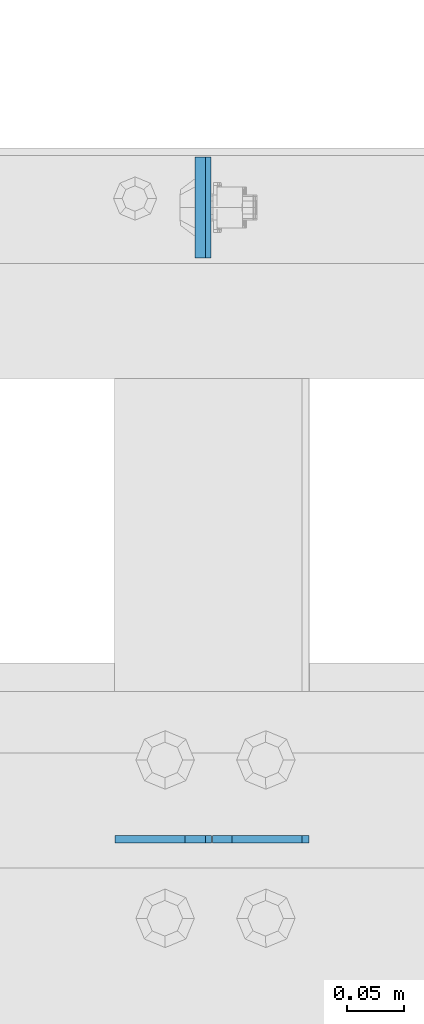
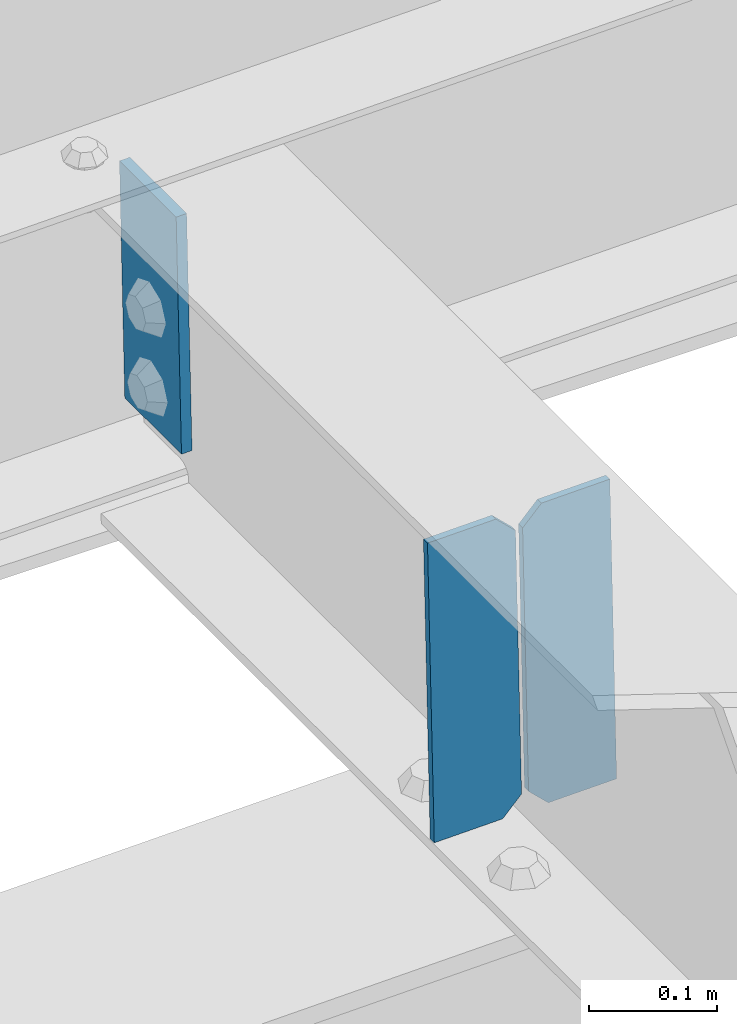
# One storey, part 3425 of 3843: 3 plates, 2 elements without a shape of their own.
"""IFC2X3 building model written with IfcOpenShell, lengths in millimetres."""

import ifcopenshell
import ifcopenshell.guid

model = None  # the IFC model being written
_history = None  # IfcOwnerHistory: only IFC2X3 demands one
_inside = {}  # id of a spatial element -> (the spatial element, [elements in it])
_under = {}  # id of a project, library or spatial element -> (it, [spatial elements below it])
_declared = {}  # id of a project -> (the project, [libraries it declares])
_typed = {}  # id of a type object -> (the type object, [elements of that type])
_made_of = {}  # id of a material, layer set ... -> (it, [elements and type objects made of it])


def new_model(schema):
    """Start an empty IFC model of exactly this schema.

    Asked for "IFC4X3", IfcOpenShell would pick the latest addendum, in which some entities
    have other attributes; the version numbers below select the first issue.
    IFC2X3 requires an IfcOwnerHistory on every rooted entity: one is made here for all.
    """
    global model, _history
    if schema == "IFC4X3":
        model = ifcopenshell.file(schema_version=(4, 3, 0, 0))
    else:
        model = ifcopenshell.file(schema=schema)
    _inside.clear()
    _under.clear()
    _declared.clear()
    _typed.clear()
    _made_of.clear()
    _history = None
    if model.schema == "IFC2X3":
        org = make("IfcOrganization", Name="unknown")
        user = make(
            "IfcPersonAndOrganization",
            ThePerson=make("IfcPerson", FamilyName="unknown"),
            TheOrganization=org,
        )
        app = make(
            "IfcApplication",
            ApplicationDeveloper=org,
            Version="unknown",
            ApplicationFullName="unknown",
            ApplicationIdentifier="unknown",
        )
        _history = make(
            "IfcOwnerHistory",
            OwningUser=user,
            OwningApplication=app,
            ChangeAction="ADDED",
            CreationDate=0,
        )
    return model


def make(cls, **values):
    """One entity of the class cls with the attributes given. An attribute that is None is left unset."""
    return model.create_entity(
        cls, **{name: value for name, value in values.items() if value is not None}
    )


def rooted(cls, **values):
    """An entity with a GlobalId (a new one), such as an element, a storey or a relation."""
    return make(cls, GlobalId=ifcopenshell.guid.new(), OwnerHistory=_history, **values)


def si_unit(unit_type, name, prefix=None):
    """IfcSIUnit, for example si_unit("LENGTHUNIT", "METRE", prefix="MILLI")."""
    return make("IfcSIUnit", UnitType=unit_type, Prefix=prefix, Name=name)


def assignment(units):
    """IfcUnitAssignment: the units of a project."""
    return None if units is None else make("IfcUnitAssignment", Units=units)


def point(xyz):
    """IfcCartesianPoint."""
    return None if xyz is None else make("IfcCartesianPoint", Coordinates=xyz)


def direction(xyz):
    """IfcDirection."""
    return None if xyz is None else make("IfcDirection", DirectionRatios=xyz)


def frame(location, z_axis=None, x_axis=None):
    """IfcAxis2Placement3D, a coordinate frame: its origin and axes. An axis left out is left unset."""
    return make(
        "IfcAxis2Placement3D",
        Location=point(location),
        Axis=direction(z_axis),
        RefDirection=direction(x_axis),
    )


def origin_with_axes():
    """The frame at (0, 0, 0) with the z axis (0, 0, 1) and the x axis (1, 0, 0) written out."""
    return frame((0.0, 0.0, 0.0), z_axis=(0.0, 0.0, 1.0), x_axis=(1.0, 0.0, 0.0))


def place(relative_to, where):
    """IfcLocalPlacement: puts the frame where relative to a parent placement (None: the world)."""
    return make(
        "IfcLocalPlacement", PlacementRelTo=relative_to, RelativePlacement=where
    )


def context(
    kind, dimensions, precision=None, world=None, true_north=None, identifier=None
):
    """IfcGeometricRepresentationContext, for example the 3D "Model" context."""
    return make(
        "IfcGeometricRepresentationContext",
        ContextIdentifier=identifier,
        ContextType=kind,
        CoordinateSpaceDimension=dimensions,
        Precision=precision,
        WorldCoordinateSystem=world,
        TrueNorth=true_north,
    )


def subcontext(parent, identifier, kind, view, scale=None):
    """IfcGeometricRepresentationSubContext, for example "Body" below "Model"."""
    return make(
        "IfcGeometricRepresentationSubContext",
        ContextIdentifier=identifier,
        ContextType=kind,
        ParentContext=parent,
        TargetScale=scale,
        TargetView=view,
    )


def project(units=None, contexts=None):
    """IfcProject with its units and contexts."""
    return rooted(
        "IfcProject",
        Name="project",
        RepresentationContexts=contexts,
        UnitsInContext=assignment(units),
    )


def spatial(cls, under=None, at=None, **own):
    """A site, building, storey or space (cls), placed at a placement, below another one or the project."""
    s = rooted(cls, ObjectPlacement=at, **own)
    if under is not None:
        _under.setdefault(under.id(), (under, []))[1].append(s)
    return s


def faces_of(points, faces, orient=None, outer=None):
    """IfcFace entities. A face is a list of loops; a loop is a list of indices into points, from 0.

    orient and outer hold one flag for each loop. By default every Orientation is true, the
    first loop of a face is its IfcFaceOuterBound and the others are IfcFaceBound.
    """
    made = []
    for i, loops in enumerate(faces):
        bounds = []
        for j, loop in enumerate(loops):
            is_outer = j == 0 if outer is None else outer[i][j]
            bounds.append(
                make(
                    "IfcFaceOuterBound" if is_outer else "IfcFaceBound",
                    Bound=make("IfcPolyLoop", Polygon=[points[k] for k in loop]),
                    Orientation=True if orient is None else orient[i][j],
                )
            )
        made.append(make("IfcFace", Bounds=bounds))
    return made


def faceted_brep(points, faces, orient=None, outer=None, voids=None):
    """IfcFacetedBrep: a solid bounded by flat faces; with voids (closed shells), ...WithVoids."""
    shared = [point(p) for p in points]
    hull = make("IfcClosedShell", CfsFaces=faces_of(shared, faces, orient, outer))
    if voids is None:
        return make("IfcFacetedBrep", Outer=hull)
    return make(
        "IfcFacetedBrepWithVoids",
        Outer=hull,
        Voids=[
            make(cls, CfsFaces=faces_of(shared, fs, o, b)) for cls, fs, o, b in voids
        ],
    )


def shape(context_of_items, identifier, shape_type, items):
    """IfcShapeRepresentation: the items that make up one representation, for example the "Body"."""
    return make(
        "IfcShapeRepresentation",
        ContextOfItems=context_of_items,
        RepresentationIdentifier=identifier,
        RepresentationType=shape_type,
        Items=items,
    )


def material(Name=None, Category=None):
    """IfcMaterial."""
    return make("IfcMaterial", Name=Name, Category=Category)


def made_of(thing, what):
    """Note that an element or type object is made of a material, layer set ...; save() writes the relation."""
    if what is not None:
        _made_of.setdefault(what.id(), (what, []))[1].append(thing)
    return thing


def type_object(cls, material=None, **own):
    """A type object (cls), such as IfcWallType, which elements share."""
    return made_of(rooted(cls, **own), material)


def element(
    cls,
    number,
    at=None,
    inside=None,
    cuts=None,
    type_object=None,
    material=None,
    context=None,
    identifier="Body",
    shape_type=None,
    held_by="IfcProductDefinitionShape",
    body=None,
    shapes=None,
    **own,
):
    """One element of the class cls, such as IfcWall. Its Tag is "e" and its number.

    at: its placement. inside: the storey or other place that contains it. cuts: it is an
    opening in that element (IfcRelVoidsElement). A single representation is given by context,
    identifier, shape_type and body (its items); several are given by shapes. held_by: the class
    of the entity that holds the representations. save() writes the other relations.
    """
    e = rooted(cls, Tag="e%d" % number, ObjectPlacement=at, **own)
    if body is not None:
        shapes = [shape(context, identifier, shape_type, body)]
    if shapes is not None:
        e.Representation = make(held_by, Representations=shapes)
    if inside is not None:
        _inside.setdefault(inside.id(), (inside, []))[1].append(e)
    if cuts is not None:
        rooted(
            "IfcRelVoidsElement", RelatingBuildingElement=cuts, RelatedOpeningElement=e
        )
    if type_object is not None:
        _typed.setdefault(type_object.id(), (type_object, []))[1].append(e)
    return made_of(e, material)


def aggregate(whole, parts):
    """IfcRelAggregates: a whole, such as a stair, and the parts it consists of."""
    return rooted("IfcRelAggregates", RelatingObject=whole, RelatedObjects=parts)


def save(model, path):
    """Write the relations noted so far, then the file.

    IfcRelAggregates (storeys below a building ...), IfcRelContainedInSpatialStructure (elements
    in a storey), IfcRelDefinesByType, IfcRelAssociatesMaterial and IfcRelDeclares: one each for
    every whole, place, type object, material and project.
    """
    for whole, parts in _under.values():
        aggregate(whole, parts)
    for where, things in _inside.values():
        rooted(
            "IfcRelContainedInSpatialStructure",
            RelatedElements=things,
            RelatingStructure=where,
        )
    for kind, things in _typed.values():
        rooted("IfcRelDefinesByType", RelatedObjects=things, RelatingType=kind)
    for what, things in _made_of.values():
        rooted("IfcRelAssociatesMaterial", RelatedObjects=things, RelatingMaterial=what)
    for by, libraries in _declared.values():
        rooted("IfcRelDeclares", RelatingContext=by, RelatedDefinitions=libraries)
    model.write(path)


model = new_model("IFC2X3")

# Units and contexts
model_context = context("Model", 3, precision=1e-05, world=origin_with_axes())
body_context = subcontext(model_context, "Body", "Model", "MODEL_VIEW")
ifc_project = project(units=[si_unit("LENGTHUNIT", "METRE", prefix="MILLI"), si_unit("AREAUNIT", "SQUARE_METRE"), si_unit("VOLUMEUNIT", "CUBIC_METRE"), si_unit("MASSUNIT", "GRAM", prefix="KILO"), si_unit("TIMEUNIT", "SECOND"), si_unit("PLANEANGLEUNIT", "RADIAN"), si_unit("SOLIDANGLEUNIT", "STERADIAN"), si_unit("THERMODYNAMICTEMPERATUREUNIT", "DEGREE_CELSIUS"), si_unit("LUMINOUSINTENSITYUNIT", "LUMEN")], contexts=[model_context])

# Site, building, storey
site_placement = place(None, origin_with_axes())
site = spatial("IfcSite", under=ifc_project, at=site_placement, CompositionType="ELEMENT")
building_placement = place(site_placement, origin_with_axes())
building = spatial("IfcBuilding", under=site, at=building_placement, Name="Undefined", CompositionType="ELEMENT")
storey_placement = place(building_placement, origin_with_axes())
storey = spatial("IfcBuildingStorey", under=building, at=storey_placement, Name="Undefined", CompositionType="ELEMENT", Elevation=0.0)

# Assembly, plate
assembly_1_placement = place(storey_placement, origin_with_axes())
assembly_1 = element("IfcElementAssembly", 1, at=assembly_1_placement, inside=storey, Name="CHANNEL", AssemblyPlace="NOTDEFINED", PredefinedType="RIGID_FRAME")
ifc_material = material(Name="STEEL/A572-50")
plate_type_1 = type_object("IfcPlateType", PredefinedType="NOTDEFINED")
plate_1_placement = place(assembly_1_placement, frame((40677.1094385553, 92816.3625149581, 45778.2643561377), z_axis=(0.0, -1.0, 0.0), x_axis=(0.0211520550054438, 0.0, -0.999776270257025)))
plate_1 = element("IfcPlate", 2, at=plate_1_placement, type_object=plate_type_1, material=ifc_material, Name="PLATE", context=body_context, shape_type="Brep", body=[
    faceted_brep([(0.0, -4.76249999999709, 0.0), (0.0, -4.76249999999709, 88.9000015258789), (0.0, 4.76249999999709, 88.9000015258789), (0.0, 4.76249999999709, 0.0), (228.600006102781, -4.7625000004191, 88.9000015257589), (228.600006102781, 4.76249999954598, 88.9000015257443), (228.600006103079, -4.7625000004482, 7.27595761418343e-12), (228.600006103079, 4.76249999954598, -7.27595761418343e-12)], [[[0, 1, 2, 3]], [[1, 4, 5, 2]], [[4, 6, 7, 5]], [[6, 0, 3, 7]], [[5, 7, 3, 2]], [[6, 4, 1, 0]]]),
])
aggregate(assembly_1, [plate_1])

# Assembly, plates
assembly_2_placement = place(storey_placement, origin_with_axes())
assembly_2 = element("IfcElementAssembly", 3, at=assembly_2_placement, inside=storey, Name="BEAM", AssemblyPlace="NOTDEFINED", PredefinedType="RIGID_FRAME")
plate_type_2 = type_object("IfcPlateType", PredefinedType="NOTDEFINED")
plate_2_placement = place(assembly_2_placement, frame((40773.0964783443, 92214.5977430504, 45518.4241901815), z_axis=(-0.0211520975410895, 0.000224553000021843, 0.999776244139439), x_axis=(-0.999776269357106, -4.75100003261494e-06, -0.0211520970075272)))
plate_2 = element("IfcPlate", 4, at=plate_2_placement, type_object=plate_type_2, material=ifc_material, Name="STIFFENER", context=body_context, shape_type="Brep", body=[
    faceted_brep([(0.0, -3.17499999999927, 0.0), (6.83940015733242e-10, -3.17499999996653, 288.924999998613), (6.54836185276508e-10, 3.17500000001746, 288.924999998591), (0.0, 3.17499999999927, 0.0), (61.9125003828667, -3.17499999997744, 288.924999998599), (61.9125003828522, 3.17500000002838, 288.924999998584), (79.3750000013097, -3.17499999997744, 271.462500380039), (79.375000001266, 3.17500000002838, 271.462500380017), (79.375000000713, -3.17499999999927, 17.4624996185448), (79.3750000006694, 3.17500000000291, 17.462499618523), (61.9125003821828, -3.17499999999563, -1.45519152283669e-11), (61.9125003821682, 3.17500000000655, -2.91038304567337e-11)], [[[0, 1, 2, 3]], [[1, 4, 5, 2]], [[4, 6, 7, 5]], [[6, 8, 9, 7]], [[8, 10, 11, 9]], [[10, 0, 3, 11]], [[5, 7, 9, 11, 3, 2]], [[10, 8, 6, 4, 1, 0]]]),
])
plate_3_placement = place(assembly_2_placement, frame((40687.3906576546, 92214.5973357862, 45516.6109266257), z_axis=(-0.0211520975410895, 0.000224553000021843, 0.999776244139439), x_axis=(-0.999776269357106, -4.75100003261494e-06, -0.0211520970075272)))
plate_3 = element("IfcPlate", 5, at=plate_3_placement, type_object=plate_type_2, material=ifc_material, Name="STIFFENER", context=body_context, shape_type="Brep", body=[
    faceted_brep([(5.82076609134674e-11, -3.17499999999927, 17.4624996185667), (6.25732354819775e-10, -3.17499999997744, 271.462500380054), (5.82076609134674e-10, 3.17500000002474, 271.462500380039), (0.0, 3.17500000000655, 17.4624996185521), (17.462499619156, -3.17499999997744, 288.924999998606), (17.4624996191269, 3.17500000002474, 288.924999998591), (79.3750000013242, -3.17500000025029, 288.924999998591), (79.3750000013097, 3.1749999997337, 288.92499999857), (79.3750000006548, -3.17500000026484, -2.18278728425503e-11), (79.3750000006403, 3.17499999969732, -2.91038304567337e-11), (17.4624996184866, -3.17500000000291, 7.27595761418343e-12), (17.462499618443, 3.17500000000291, -7.27595761418343e-12)], [[[0, 1, 2, 3]], [[1, 4, 5, 2]], [[4, 6, 7, 5]], [[6, 8, 9, 7]], [[8, 10, 11, 9]], [[10, 0, 3, 11]], [[5, 7, 9, 11, 3, 2]], [[10, 8, 6, 4, 1, 0]]]),
])
aggregate(assembly_2, [plate_2, plate_3])

save(model, "model.ifc")
